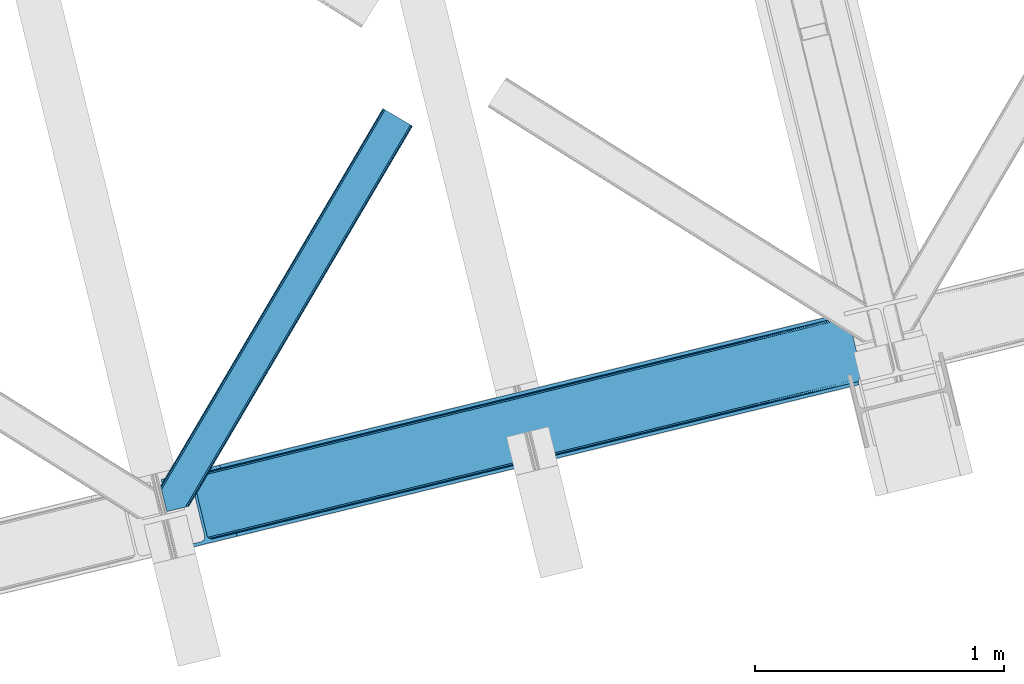
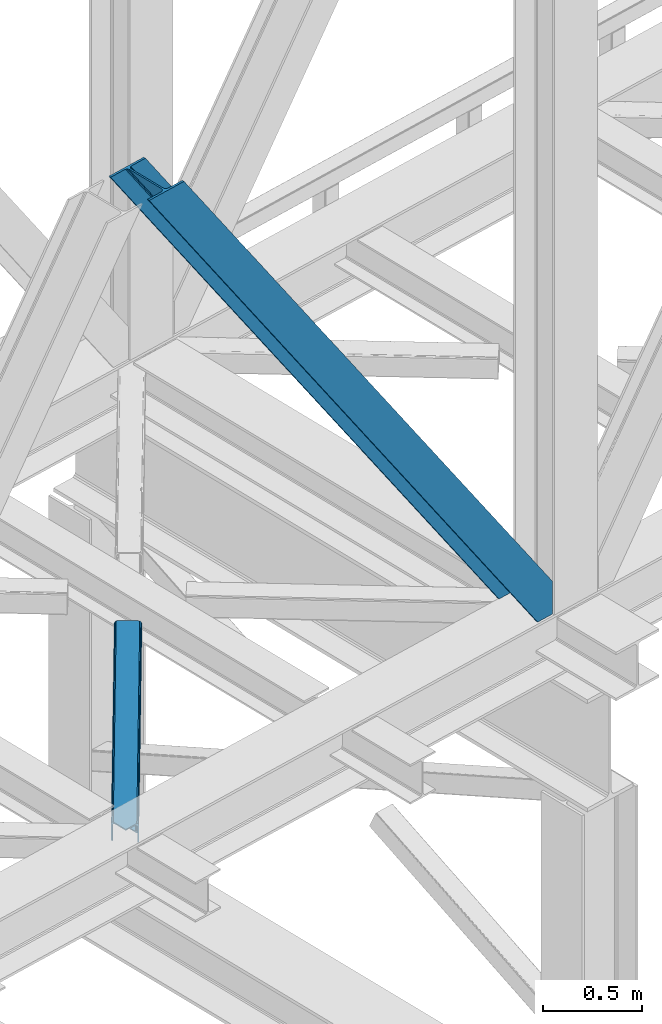
# One storey, part 27 of 93: 2 members.
"""IFC4 building model written with IfcOpenShell, lengths in millimetres."""

from ifc_helpers import new_model, entity, si_unit, converted_unit, derived_unit, direction, frame, origin, place, context, subcontext, project, spatial, triangles, type_object, element, save


model = new_model("IFC4")

# Units and contexts
model_context = context("Model", 3, precision=0.01, world=origin(), true_north=direction((6.12303176911189e-17, 1.0)))
plan_context = context("Plan", 3, precision=0.01, world=origin(), true_north=direction((6.12303176911189e-17, 1.0)))
body_context = subcontext(model_context, "Body", "Model", "MODEL_VIEW")
ifc_project = project(units=[si_unit("LENGTHUNIT", "METRE", prefix="MILLI"), si_unit("AREAUNIT", "SQUARE_METRE"), si_unit("VOLUMEUNIT", "CUBIC_METRE"), converted_unit("PLANEANGLEUNIT", "DEGREE", entity("IfcRatioMeasure", 0.0174532925199433), si_unit("PLANEANGLEUNIT", "RADIAN"), dimensions=[0, 0, 0, 0, 0, 0, 0]), si_unit("MASSUNIT", "GRAM", prefix="KILO"), derived_unit("MASSDENSITYUNIT", [(si_unit("MASSUNIT", "GRAM", prefix="KILO"), 1), (si_unit("LENGTHUNIT", "METRE"), -3)]), derived_unit("MOMENTOFINERTIAUNIT", [(si_unit("LENGTHUNIT", "METRE"), 4)]), si_unit("TIMEUNIT", "SECOND"), si_unit("FREQUENCYUNIT", "HERTZ"), si_unit("THERMODYNAMICTEMPERATUREUNIT", "DEGREE_CELSIUS"), derived_unit("THERMALTRANSMITTANCEUNIT", [(si_unit("MASSUNIT", "GRAM", prefix="KILO"), 1), (si_unit("THERMODYNAMICTEMPERATUREUNIT", "KELVIN"), -1), (si_unit("TIMEUNIT", "SECOND"), -3)]), derived_unit("VOLUMETRICFLOWRATEUNIT", [(si_unit("LENGTHUNIT", "METRE"), 3), (si_unit("TIMEUNIT", "SECOND"), -1)]), derived_unit("MASSFLOWRATEUNIT", [(si_unit("MASSUNIT", "GRAM", prefix="KILO"), 1), (si_unit("TIMEUNIT", "SECOND"), -1)]), derived_unit("ROTATIONALFREQUENCYUNIT", [(si_unit("TIMEUNIT", "SECOND"), -1)]), si_unit("ELECTRICCURRENTUNIT", "AMPERE"), si_unit("ELECTRICVOLTAGEUNIT", "VOLT"), si_unit("POWERUNIT", "WATT"), si_unit("FORCEUNIT", "NEWTON", prefix="KILO"), si_unit("ILLUMINANCEUNIT", "LUX"), si_unit("LUMINOUSFLUXUNIT", "LUMEN"), si_unit("LUMINOUSINTENSITYUNIT", "CANDELA"), derived_unit("USERDEFINED", [(si_unit("MASSUNIT", "GRAM", prefix="KILO"), -1), (si_unit("LENGTHUNIT", "METRE"), -2), (si_unit("TIMEUNIT", "SECOND"), 3), (si_unit("LUMINOUSFLUXUNIT", "LUMEN"), 1)]), derived_unit("LINEARVELOCITYUNIT", [(si_unit("LENGTHUNIT", "METRE"), 1), (si_unit("TIMEUNIT", "SECOND"), -1)]), si_unit("PRESSUREUNIT", "PASCAL"), derived_unit("USERDEFINED", [(si_unit("LENGTHUNIT", "METRE"), -2), (si_unit("MASSUNIT", "GRAM", prefix="KILO"), 1), (si_unit("TIMEUNIT", "SECOND"), -2)]), derived_unit("LINEARFORCEUNIT", [(si_unit("MASSUNIT", "GRAM", prefix="KILO"), 1), (si_unit("LENGTHUNIT", "METRE"), 1), (si_unit("TIMEUNIT", "SECOND"), -2), (si_unit("LENGTHUNIT", "METRE"), -1)]), derived_unit("PLANARFORCEUNIT", [(si_unit("MASSUNIT", "GRAM", prefix="KILO"), 1), (si_unit("LENGTHUNIT", "METRE"), 1), (si_unit("TIMEUNIT", "SECOND"), -2), (si_unit("LENGTHUNIT", "METRE"), -2)])], contexts=[model_context, plan_context])

# Site, building, storey
site_placement = place(None, origin())
site = spatial("IfcSite", under=ifc_project, at=site_placement, CompositionType="ELEMENT")
building_placement = place(site_placement, origin())
building = spatial("IfcBuilding", under=site, at=building_placement, CompositionType="ELEMENT")
storey_placement = place(building_placement, frame((0.0, 0.0, 15900.0)))
storey = spatial("IfcBuildingStorey", under=building, at=storey_placement, CompositionType="ELEMENT", Elevation=15900.0)

# Members
member_type_1 = type_object("IfcMemberType", PredefinedType="BRACE")
member_1_placement = place(storey_placement, frame((-57373.986328125, 3481.27180938721, 3694.99929199219)))
element("IfcMember", 1, at=member_1_placement, inside=storey, type_object=member_type_1, ObjectType="Steel Vertical Brace", PredefinedType="BRACE", context=body_context, shape_type="Tessellation", body=[
    triangles([(2824.17180175781, 696.209248352051, 0.781347656247817), (2824.8368774414, 695.2276222229, 1.0697021484375), (2823.33929443359, 694.862528228759, 0.0), (2821.44638671875, 702.635018920899, 0.0), (2812.37717285156, 692.190598297119, 19.5569458007813), (2812.37717285156, 692.190598297119, 0.0), (2386.756640625, 583.574263000488, 658.75048828125), (2392.34234619141, 580.919773864746, 662.07819213867), (2803.98698730468, 681.26248626709, 51.2480346679658), (2804.11256103515, 683.186496734619, 44.4996093749978), (2382.25924072265, 588.488497924805, 656.525042724606), (2808.48903808594, 690.37995300293, 26.4030395507798), (2805.01948242187, 685.664543151855, 38.2720825195283), (2805.58688964844, 687.218227386475, 34.3676696777329), (630.519653320313, 150.046073913574, 3288.98063964843), (624.69210205078, 150.036772155762, 3285.05529785156), (211.331286621091, 47.8653923034667, 3911.00081176758), (202.862036132814, 47.2113624572753, 3911.00081176758), (619.106396484371, 152.691261291504, 3281.72759399414), (195.034606933594, 49.3190826416017, 3911.00081176758), (614.608996582028, 157.60549621582, 3279.50447387695), (189.039624023433, 53.8679328918456, 3911.00081176758), (611.88358154297, 164.031266784668, 3278.7231262207), (185.788659667967, 60.1655136108398, 3911.00081176758), (2804.10325927734, 679.880593872071, 63.6403015136711), (2398.16524658203, 580.929075622559, 666.003533935545), (1956.25268554688, 473.208325195313, 1321.74955444336), (1950.42978515625, 473.1990234375, 1317.82188720703), (1508.51722412109, 365.478273010254, 1973.56790771484), (1514.34012451172, 365.487574768066, 1977.49324951172), (1066.60466308593, 257.757522583008, 2629.3116027832), (1072.42756347656, 257.76682434082, 2633.23694458008), (1944.84407958984, 475.853512573242, 1314.49418334961), (1502.93151855469, 368.132762145996, 1970.23787841797), (1061.01895751953, 260.41201171875, 2625.98389892578), (1940.3466796875, 480.767747497559, 1312.27106323242), (1498.43411865235, 373.046997070313, 1968.01475830078), (1056.52155761718, 265.326246643067, 2623.75845336914), (2379.53382568359, 594.913977813721, 655.74602050781), (1937.62126464843, 487.193518066406, 1311.48971557617), (1495.70870361328, 379.47276763916, 1967.23341064453), (1053.79614257813, 271.752017211914, 2622.97710571289), (2766.2637084961, 929.006666564941, 0.0), (2324.35114746093, 821.285625457764, 655.74602050781), (1882.43858642578, 713.565165710449, 1311.48971557617), (1440.53067626953, 605.844415283203, 1967.23341064453), (998.618115234371, 498.123664855957, 2622.97710571289), (556.705554199216, 390.402914428711, 3278.7231262207), (130.605981445311, 286.537161254883, 3911.00081176758), (303.265209960933, 70.2747802734375, 3911.00081176758), (2804.10325927734, 679.880593872071, 200.055230712889), (2807.14028320312, 667.239795684814, 200.120343017577), (2804.2985961914, 678.898386383056, 200.120343017577), (306.344091796876, 57.6444465637205, 3911.00081176758), (2807.14028320312, 667.239795684814, 0.0), (2804.2985961914, 678.898386383056, 0.0), (2804.0009399414, 682.092958831787, 0.0), (2804.11256103515, 683.186496734619, 2.42078247070094), (2804.71717529296, 685.456997680664, 5.12991943359157), (2805.58688964844, 687.218227386475, 5.67639770507594), (2807.01470947266, 689.087299346924, 4.89505004882813), (2808.48903808594, 690.37995300293, 3.35328369140552), (2811.03771972656, 691.772309875489, 0.0), (2705.52322998047, 642.46979598999, 0.0), (69.865502929686, 0.0, 3911.00081176758), (2794.37362060547, 677.509226989746, 0.0), (2802.00106201172, 681.140400695801, 0.0), (2702.44434814453, 655.099839019776, 0.0), (66.78662109375, 12.6303337097165, 3911.00081176758), (1480.00268554688, 357.116864776611, 1950.37164916992), (1034.29035644531, 248.469426727295, 2611.75686035156), (588.573376464839, 139.821988677978, 3273.1420715332), (158.715893554683, 35.039430999756, 3911.00081176758), (1925.71501464843, 465.764302825928, 1288.98643798828), (2371.42734375, 574.411740875244, 627.598901367186), (2376.60377197265, 577.083380126953, 631.526568603513), (2380.34307861328, 582.010695648193, 634.854272460936), (2381.53835449219, 595.402610778809, 637.858740234373), (2811.39583740234, 700.184877777099, 0.0), (2811.09353027344, 693.083567047119, 0.0), (2382.0732055664, 588.443733215332, 637.077392578125), (598.679736328122, 160.812567901611, 3283.40191040039), (599.21923828125, 153.853690338135, 3282.62056274414), (175.738110351558, 57.7156631469725, 3911.00081176758), (175.747412109376, 50.6283050537108, 3911.00081176758), (597.489111328126, 147.420943450928, 3280.39744262695), (172.519702148435, 43.8301734924316, 3911.00081176758), (593.749804687497, 142.493627929688, 3277.06973876953), (166.538671875001, 38.3560890197755, 3911.00081176758), (1936.36087646485, 479.796004486084, 1298.46260375976), (1935.82137451172, 486.755172729492, 1299.24395141601), (1490.10904541016, 378.107734680176, 1960.63148803711), (1490.64854736328, 371.148566436767, 1959.85014038086), (1044.93156738281, 262.501128387451, 2621.2353515625), (1044.39671630859, 269.460296630859, 2622.01669921875), (1934.62609863281, 473.363257598877, 1296.23948364258), (1488.91376953125, 364.71581954956, 1957.62469482422), (1043.20144042969, 256.068381500244, 2619.01223144531), (1930.89144287109, 468.435942077637, 1292.91177978515), (1485.17911376953, 359.78850402832, 1954.2969909668), (1039.46213378906, 251.141065979004, 2615.68220214844), (2756.21315917969, 926.556525421142, 0.0), (2326.35567626953, 821.774258422852, 637.858740234373), (1434.9263671875, 604.479382324219, 1960.63148803711), (1880.64334716797, 713.126820373535, 1299.24395141601), (989.214038085935, 495.831944274903, 2622.01669921875), (543.501708984375, 387.184215545654, 3283.40191040039), (120.555432128902, 284.087310791016, 3911.00081176758), (2752.67849121094, 932.72359085083, 0.0), (2753.40867919922, 934.106936645508, 0.0), (2752.02736816406, 933.862474822998, 0.0), (2764.37080078125, 936.778866577149, 0.0), (2753.40867919922, 934.106936645508, 19.5569458007813), (2765.86838378906, 937.143960571289, 1.0697021484375), (2765.72885742188, 935.965544128418, 0.781347656247817), (2325.54642333985, 834.677540588379, 658.75048828125), (2749.12056884765, 933.923517608642, 26.4030395507798), (2745.08825683594, 935.395230102539, 34.3676696777329), (2323.81629638671, 828.244793701172, 656.525042724606), (2743.51160888671, 936.560275268555, 38.5441589355469), (556.166052246095, 397.361791992188, 3279.50447387695), (130.5966796875, 293.624228668213, 3911.00081176758), (557.900830078121, 403.794829559326, 3281.72759399414), (133.824389648435, 300.422360229492, 3911.00081176758), (561.635485839841, 408.721854400635, 3285.05529785156), (139.805419921875, 305.896444702149, 3911.00081176758), (566.811914062499, 411.393493652344, 3288.98063964843), (147.628198242186, 309.213102722168, 3911.00081176758), (2740.93037109375, 939.947568511963, 51.2480346679658), (2740.39552001953, 941.228304290771, 63.6403015136711), (2329.28572998047, 839.60485610962, 662.07819213867), (2334.45750732422, 842.276495361328, 666.003533935545), (2742.09309082031, 938.42149887085, 45.5251281738274), (1881.90373535156, 720.524043273926, 1312.27106323242), (1439.9911743164, 612.80329284668, 1968.01475830078), (998.07861328125, 505.082542419434, 2623.75845336914), (1883.63386230468, 726.956790161133, 1314.49418334961), (1441.72130126953, 619.236039733887, 1970.23787841797), (999.813391113283, 511.515289306641, 2625.98389892578), (1887.37316894531, 731.884105682373, 1317.82188720703), (1445.46060791016, 624.163355255127, 1973.56790771484), (1003.548046875, 516.442604827881, 2629.3116027832), (1892.54959716797, 734.555744934082, 1321.74955444336), (1450.63703613281, 626.834994506836, 1977.49324951172), (1008.72447509765, 519.11424407959, 2633.23694458008), (2740.39552001953, 941.228304290771, 200.055230712889), (239.557470703126, 331.622200012207, 3911.00081176758), (2749.12056884765, 933.923517608642, 3.35328369140552), (2745.08825683594, 935.395230102539, 5.67639770507594), (2747.2230102539, 934.392675018311, 4.89272460937354), (2743.51160888671, 936.560275268555, 5.12991943359157), (2740.11646728515, 942.189001464843, 0.0), (2741.92565917969, 938.297378540039, 2.42078247070094), (2740.11646728515, 942.189001464843, 200.120343017577), (2741.32104492188, 939.215927124023, 0.0), (2323.63026123046, 828.2000289917, 637.077392578125), (2319.13286132812, 833.113973236084, 634.854272460936), (2313.54715576172, 835.768462371826, 631.526568603513), (2307.72425537109, 835.759160614014, 627.598901367186), (2730.67053222656, 938.856646728515, 0.0), (2739.1072265625, 939.141222381591, 0.0), (524.870288085935, 401.16969909668, 3273.1420715332), (530.693188476558, 401.17871017456, 3277.06973876953), (103.477404785153, 297.041171264648, 3911.00081176758), (95.0081542968765, 296.387141418457, 3911.00081176758), (536.278894042967, 398.524221038818, 3280.39744262695), (111.309484863283, 294.933451080322, 3911.00081176758), (540.77629394531, 393.609986114502, 3282.62056274414), (117.304467773436, 290.384600830078, 3911.00081176758), (1867.83482666015, 727.12102432251, 1292.91177978515), (1862.01192626953, 727.112013244629, 1288.98643798828), (1416.29494628906, 618.464575195312, 1950.37164916992), (1422.11784667968, 618.473586273193, 1954.2969909668), (970.582617187501, 509.817137145996, 2611.75686035156), (976.405517578125, 509.826148223877, 2615.68220214844), (1873.42053222656, 724.466535186768, 1296.23948364258), (1427.70355224609, 615.819097137452, 1957.62469482422), (981.991223144527, 507.171659088135, 2619.01223144531), (1877.9179321289, 719.552300262451, 1298.46260375976), (1432.20560302735, 610.905152893066, 1959.85014038086), (986.488623046876, 502.257424163819, 2621.2353515625), (2737.27478027344, 953.847592163086, 200.120343017577), (236.478588867183, 344.252533721924, 3911.00081176758), (2737.27478027344, 953.847592163086, 0.0), (0.0, 286.608087158203, 3911.00081176758), (3.07888183593604, 273.977753448487, 3911.00081176758), (2635.65772705078, 929.077592468262, 0.0), (2638.73660888672, 916.447258758545, 0.0)], [[1, 2, 3], [3, 4, 1], [2, 5, 6], [6, 3, 2], [7, 8, 9], [9, 10, 7], [11, 12, 5], [5, 1, 11], [5, 2, 1], [11, 7, 13], [13, 14, 11], [14, 12, 11], [15, 16, 17], [18, 17, 16], [16, 19, 18], [20, 18, 19], [19, 21, 20], [22, 20, 21], [21, 23, 22], [24, 22, 23], [10, 13, 7], [25, 9, 8], [8, 26, 25], [26, 8, 27], [28, 27, 8], [27, 28, 29], [29, 30, 27], [30, 29, 31], [31, 32, 30], [32, 31, 16], [16, 15, 32], [8, 7, 28], [33, 28, 7], [28, 33, 29], [34, 29, 33], [29, 34, 31], [35, 31, 34], [31, 35, 19], [19, 16, 31], [7, 11, 36], [36, 33, 7], [33, 36, 37], [37, 34, 33], [34, 37, 35], [38, 35, 37], [35, 38, 19], [21, 19, 38], [1, 4, 39], [39, 11, 1], [11, 39, 40], [40, 36, 11], [36, 40, 41], [41, 37, 36], [37, 41, 42], [42, 38, 37], [38, 42, 21], [23, 21, 42], [4, 43, 44], [45, 39, 44], [41, 40, 45], [41, 45, 46], [44, 39, 4], [45, 40, 39], [42, 41, 46], [46, 47, 42], [47, 48, 23], [49, 24, 48], [47, 23, 42], [48, 24, 23], [50, 51, 30], [30, 32, 50], [32, 15, 50], [17, 50, 15], [27, 30, 51], [51, 25, 26], [26, 27, 51], [52, 53, 54], [53, 51, 50], [50, 54, 53], [52, 55, 53], [56, 53, 55], [56, 9, 25], [56, 57, 58], [58, 10, 56], [10, 9, 56], [59, 60, 14], [14, 13, 59], [10, 58, 59], [60, 61, 12], [12, 14, 60], [5, 62, 63], [63, 6, 5], [5, 12, 62], [61, 62, 12], [13, 10, 59], [25, 51, 53], [53, 56, 25], [54, 64, 52], [54, 65, 64], [64, 55, 52], [56, 66, 67], [55, 66, 56], [67, 57, 56], [64, 66, 55], [64, 68, 66], [68, 64, 65], [65, 69, 68], [69, 70, 68], [71, 69, 72], [69, 71, 70], [69, 73, 72], [74, 68, 70], [66, 68, 75], [74, 75, 68], [67, 76, 58], [76, 77, 59], [59, 58, 76], [76, 67, 66], [78, 79, 80], [81, 60, 59], [81, 80, 62], [62, 61, 81], [61, 60, 81], [80, 63, 62], [59, 77, 81], [80, 81, 78], [82, 83, 84], [85, 84, 83], [83, 86, 85], [87, 85, 86], [86, 88, 87], [89, 87, 88], [88, 72, 89], [73, 89, 72], [66, 75, 76], [58, 57, 67], [78, 81, 90], [90, 91, 78], [91, 90, 92], [93, 92, 90], [92, 93, 94], [94, 95, 92], [95, 94, 83], [83, 82, 95], [81, 77, 90], [96, 90, 77], [90, 96, 93], [97, 93, 96], [93, 97, 94], [98, 94, 97], [94, 98, 83], [86, 83, 98], [77, 76, 99], [99, 96, 77], [96, 99, 100], [100, 97, 96], [97, 100, 101], [101, 98, 97], [98, 101, 86], [88, 86, 101], [76, 75, 99], [74, 99, 75], [99, 74, 70], [70, 100, 99], [100, 70, 71], [71, 101, 100], [101, 71, 88], [72, 88, 71], [102, 79, 78], [91, 103, 78], [104, 105, 91], [104, 91, 92], [78, 103, 102], [91, 105, 103], [106, 104, 92], [92, 95, 106], [95, 82, 107], [84, 108, 82], [95, 107, 106], [82, 108, 107], [109, 102, 110], [6, 79, 80], [6, 80, 63], [110, 111, 109], [3, 79, 6], [79, 4, 102], [3, 4, 79], [43, 102, 4], [102, 112, 110], [112, 102, 43], [113, 114, 110], [112, 110, 114], [114, 115, 112], [43, 112, 115], [116, 117, 118], [119, 115, 113], [113, 116, 119], [113, 117, 116], [115, 114, 113], [118, 120, 116], [48, 121, 122], [122, 49, 48], [121, 123, 124], [124, 122, 121], [123, 125, 126], [126, 124, 123], [125, 127, 128], [128, 126, 125], [129, 130, 131], [132, 131, 130], [133, 116, 120], [116, 133, 129], [131, 116, 129], [43, 115, 119], [119, 44, 43], [44, 119, 45], [134, 45, 119], [45, 134, 46], [135, 46, 134], [46, 135, 47], [136, 47, 135], [47, 136, 121], [121, 48, 47], [119, 116, 134], [137, 134, 116], [134, 137, 135], [138, 135, 137], [135, 138, 139], [139, 136, 135], [136, 139, 121], [123, 121, 139], [116, 131, 140], [140, 137, 116], [137, 140, 141], [141, 138, 137], [138, 141, 142], [142, 139, 138], [139, 142, 123], [125, 123, 142], [131, 132, 140], [143, 140, 132], [140, 143, 141], [144, 141, 143], [141, 144, 142], [145, 142, 144], [142, 145, 125], [127, 125, 145], [144, 146, 147], [147, 127, 145], [127, 147, 128], [145, 144, 147], [146, 144, 143], [143, 132, 146], [130, 146, 132], [113, 110, 111], [148, 117, 113], [149, 118, 117], [117, 148, 150], [151, 133, 120], [118, 149, 151], [151, 120, 118], [152, 133, 153], [152, 129, 133], [146, 130, 154], [152, 154, 130], [130, 129, 152], [153, 155, 152], [151, 153, 133], [117, 150, 149], [111, 148, 113], [156, 150, 148], [156, 149, 150], [148, 109, 156], [148, 111, 109], [156, 157, 151], [151, 149, 156], [103, 156, 109], [158, 159, 160], [158, 153, 151], [158, 161, 153], [161, 155, 153], [151, 157, 158], [160, 161, 158], [162, 163, 164], [164, 165, 162], [163, 166, 167], [167, 164, 163], [166, 168, 169], [169, 167, 166], [168, 107, 108], [108, 169, 168], [109, 102, 103], [159, 158, 170], [170, 171, 159], [171, 170, 172], [173, 172, 170], [172, 173, 174], [175, 174, 173], [174, 175, 162], [163, 162, 175], [158, 157, 170], [176, 170, 157], [170, 176, 173], [177, 173, 176], [173, 177, 175], [178, 175, 177], [175, 178, 166], [166, 163, 175], [157, 156, 179], [179, 176, 157], [176, 179, 180], [180, 177, 176], [177, 180, 181], [181, 178, 177], [178, 181, 166], [168, 166, 181], [156, 103, 179], [105, 179, 103], [179, 105, 104], [104, 180, 179], [180, 104, 181], [106, 181, 104], [181, 106, 168], [107, 168, 106], [146, 154, 147], [154, 182, 183], [183, 147, 154], [154, 152, 184], [184, 182, 154], [108, 84, 49], [87, 89, 18], [73, 65, 54], [69, 65, 73], [89, 73, 17], [84, 85, 22], [85, 87, 20], [167, 126, 164], [185, 165, 183], [165, 164, 128], [185, 186, 165], [167, 169, 124], [169, 108, 122], [49, 84, 24], [17, 18, 89], [22, 85, 20], [18, 20, 87], [22, 24, 84], [54, 17, 73], [54, 50, 17], [128, 164, 126], [124, 169, 122], [49, 122, 108], [124, 126, 167], [128, 183, 165], [183, 128, 147], [152, 160, 184], [155, 161, 152], [152, 161, 160], [160, 187, 184], [187, 160, 188], [183, 187, 185], [187, 183, 182], [184, 187, 182], [172, 186, 188], [162, 186, 174], [162, 165, 186], [172, 174, 186], [188, 171, 172], [159, 171, 188], [188, 160, 159], [187, 188, 185], [186, 185, 188]]),
])
member_type_2 = type_object("IfcMemberType", PredefinedType="BRACE")
member_2_placement = place(storey_placement, frame((-57375.3955444336, 3638.09770202637, 3511.0000579834)))
element("IfcMember", 2, at=member_2_placement, inside=storey, type_object=member_type_2, ObjectType="Steel Horizontal Brace", PredefinedType="BRACE", context=body_context, shape_type="Tessellation", body=[
    triangles([(154.446386718751, 124.708666992188, 0.0), (118.769494628905, 271.071535491943, 0.0), (998.971582031249, 1559.19843292236, 0.0), (908.488732910155, 1612.46901855469, 0.0), (1004.74332275391, 1555.80096588135, 1.33247680664135), (156.725317382814, 115.37377166748, 1.33247680664135), (1009.63604736328, 1552.92090911865, 5.12526855468968), (158.650781249999, 107.459719848633, 5.12526855468968), (1012.90561523438, 1550.99602661133, 10.8028289794929), (159.943725585938, 102.171670532227, 10.8028289794929), (1014.05438232422, 1550.3204864502, 17.5000946044929), (160.394860839842, 100.314807128907, 17.5000946044929), (902.716992187503, 1615.8664855957, 1.33247680664135), (116.495214843751, 280.406721496582, 1.33247680664135), (114.574401855469, 288.275717926026, 5.17061462402489), (897.824267578122, 1618.74712371826, 5.12526855468968), (114.499987792966, 288.596628570557, 5.32641906738354), (894.554699707034, 1620.67142486572, 10.8028289794929), (109.625866699222, 287.409201049805, 10.8028289794929), (893.405932617185, 1621.34696502686, 17.5000946044929), (107.821325683595, 286.969111633301, 17.5000946044929), (113.527954101563, 288.35972442627, 18.5197998046897), (114.499987792966, 288.596628570557, 17.5198608398459), (114.42557373047, 288.578606414795, 17.9023956298843), (114.216284179689, 288.527156066895, 18.2279571533218), (113.900024414063, 288.450416564941, 18.4442230224631), (107.821325683595, 286.969111633301, 18.5197998046897), (115.695263671878, 283.683556365967, 17.5198608398459), (115.625500488284, 283.800409698486, 17.8035644531265), (115.565039062501, 283.740529632569, 17.8570495605491), (115.323193359378, 283.495777130127, 18.0768035888686), (115.067395019534, 283.23939743042, 18.3081848144539), (114.834851074222, 283.003074645996, 18.5197998046897), (0.0, 103.824767303467, 18.5197998046897), (2.73471679687646, 92.5989990234375, 18.5197998046897), (893.405932617185, 1621.34696502686, 122.500662231447), (0.0, 103.824767303467, 122.500662231447), (908.488732910155, 1612.46901855469, 139.999594116212), (902.716992187503, 1615.8664855957, 138.667117309571), (3.66954345702834, 88.7660934448245, 138.667117309571), (5.94847412109084, 79.4309074401858, 139.999594116212), (897.824267578122, 1618.74712371826, 134.874325561526), (1.73942871093459, 96.6798545837405, 134.874325561526), (894.554699707034, 1620.67142486572, 129.197927856447), (0.451135253904795, 101.967903900147, 129.197927856447), (899.438122558597, 1617.79601898193, 24.4996673583992), (2.37659912109666, 94.0672233581545, 24.4996673583992), (900.586889648439, 1617.11989746094, 17.8035644531265), (903.856457519534, 1615.19559631348, 12.1260040283232), (914.52092285156, 1608.9174911499, 6.99957275390625), (908.749182128908, 1612.31495819092, 8.3320495605476), (118.871813964841, 270.64917755127, 8.3320495605476), (121.150744628903, 261.313991546631, 6.99957275390625), (116.946350097656, 278.562938690186, 12.1260040283232), (152.069787597655, 134.4662109375, 6.99957275390625), (992.939392089844, 1562.74996032715, 6.99957275390625), (156.274182128909, 117.217263793946, 12.1260040283232), (154.344067382815, 125.131024932862, 8.3320495605476), (157.520617675778, 112.096646118164, 17.5198608398459), (160.394860839842, 100.314807128907, 17.5198608398459), (899.438122558597, 1617.79601898193, 115.501089477541), (2.37659912109666, 94.0672233581545, 115.501089477541), (900.586889648439, 1617.11989746094, 122.196029663086), (2.83238525390334, 92.2103599548341, 122.196029663086), (903.856457519534, 1615.19559631348, 127.87475280762), (4.12067871094041, 86.9223106384279, 127.87475280762), (908.749182128908, 1612.31495819092, 131.667544555665), (6.05079345703416, 79.0085494995119, 131.667544555665), (914.52092285156, 1608.9174911499, 133.000021362306), (8.3250732421875, 69.6733634948732, 133.000021362306), (25.310083007811, 0.0, 133.000021362306), (25.310083007811, 0.0, 139.999594116212), (90.3665771484375, 15.8580436706543, 139.999594116212), (998.971582031249, 1559.19843292236, 139.999594116212), (1014.05438232422, 1550.3204864502, 122.500662231447), (1012.90561523438, 1550.99602661133, 129.197927856447), (114.076757812501, 21.6376327514649, 122.500662231447), (112.267565917966, 21.1978340148926, 129.197927856447), (1009.63604736328, 1552.92090911865, 134.874325561526), (107.12834472656, 19.9450035095215, 134.874325561526), (1004.74332275391, 1555.80096588135, 138.667117309571), (99.435791015625, 18.0698272705081, 138.667117309571), (159.664672851563, 99.0785453796389, 18.5197998046897), (114.076757812501, 21.6376327514649, 18.5197998046897), (103.161145019534, 18.9779113769532, 18.5197998046897), (156.929956054686, 110.304313659668, 18.5197998046897), (1008.02219238281, 1553.87143249512, 24.4996673583992), (1006.87342529297, 1554.54755401611, 17.8035644531265), (1003.60385742188, 1556.47185516357, 12.1260040283232), (998.711132812503, 1559.35249328613, 8.3320495605476), (104.588964843751, 19.325855255127, 24.4996673583992), (1003.60385742188, 1556.47185516357, 127.87475280762), (1008.02219238281, 1553.87143249512, 115.501089477541), (1006.87342529297, 1554.54755401611, 122.196029663086), (992.939392089844, 1562.74996032715, 133.000021362306), (998.711132812503, 1559.35249328613, 131.667544555665), (102.784423828125, 18.8860565185546, 122.196029663086), (80.8787841796875, 13.5462661743163, 133.000021362306), (89.9526489257842, 15.7580497741701, 131.667544555665), (97.6452026367188, 17.6329353332521, 127.87475280762), (104.588964843751, 19.325855255127, 115.501089477541)], [[1, 2, 3], [4, 3, 2], [3, 5, 1], [6, 1, 5], [5, 7, 6], [8, 6, 7], [7, 9, 8], [10, 8, 9], [9, 11, 10], [12, 10, 11], [13, 14, 15], [16, 15, 17], [17, 18, 16], [17, 19, 18], [20, 18, 19], [19, 21, 20], [15, 16, 13], [13, 4, 14], [2, 14, 4], [22, 23, 24], [22, 25, 26], [27, 21, 22], [24, 25, 22], [23, 22, 21], [21, 19, 23], [17, 23, 19], [23, 28, 29], [29, 24, 23], [25, 24, 30], [26, 25, 31], [22, 26, 32], [32, 33, 22], [31, 32, 26], [30, 31, 25], [29, 30, 24], [34, 33, 35], [33, 34, 27], [22, 33, 27], [27, 20, 21], [36, 27, 37], [27, 36, 20], [27, 34, 37], [38, 39, 40], [40, 41, 38], [39, 42, 43], [43, 40, 39], [42, 44, 45], [45, 43, 42], [44, 36, 37], [37, 45, 44], [46, 47, 33], [33, 48, 46], [33, 31, 48], [47, 35, 33], [49, 48, 28], [50, 51, 52], [52, 53, 50], [51, 49, 54], [54, 52, 51], [28, 54, 49], [53, 55, 56], [56, 50, 53], [55, 2, 1], [54, 17, 14], [52, 14, 2], [52, 2, 53], [55, 53, 2], [17, 28, 23], [54, 28, 17], [52, 54, 14], [57, 58, 6], [58, 1, 6], [1, 58, 55], [8, 57, 6], [8, 59, 57], [10, 59, 8], [10, 60, 59], [46, 61, 47], [62, 47, 61], [61, 63, 62], [64, 62, 63], [63, 65, 64], [66, 64, 65], [65, 67, 66], [68, 66, 67], [67, 69, 68], [70, 68, 69], [66, 43, 64], [71, 72, 70], [72, 41, 70], [40, 68, 41], [66, 68, 40], [68, 70, 41], [66, 40, 43], [37, 34, 62], [45, 64, 43], [62, 64, 37], [64, 45, 37], [34, 47, 62], [34, 35, 47], [41, 73, 74], [73, 41, 72], [74, 38, 41], [75, 76, 77], [78, 77, 76], [76, 79, 78], [80, 78, 79], [79, 81, 80], [82, 80, 81], [81, 74, 82], [73, 82, 74], [60, 75, 77], [60, 11, 75], [77, 83, 60], [77, 84, 83], [84, 85, 83], [86, 83, 85], [87, 88, 59], [88, 89, 57], [57, 59, 88], [89, 90, 58], [58, 57, 89], [90, 56, 55], [55, 58, 90], [87, 86, 91], [85, 91, 86], [9, 89, 88], [87, 75, 11], [9, 88, 11], [9, 7, 89], [88, 87, 11], [89, 7, 5], [56, 3, 4], [3, 90, 5], [90, 3, 56], [90, 89, 5], [76, 92, 79], [93, 75, 87], [75, 94, 76], [94, 75, 93], [76, 94, 92], [74, 95, 38], [81, 79, 92], [92, 96, 81], [96, 95, 74], [74, 81, 96], [49, 13, 16], [4, 50, 56], [4, 51, 50], [51, 4, 13], [49, 51, 13], [46, 20, 36], [18, 48, 49], [16, 18, 49], [48, 18, 20], [46, 48, 20], [39, 65, 42], [38, 95, 69], [69, 67, 38], [67, 65, 39], [39, 38, 67], [44, 42, 65], [36, 61, 46], [63, 36, 44], [36, 63, 61], [63, 44, 65], [97, 78, 80], [98, 73, 72], [72, 71, 98], [98, 99, 73], [99, 82, 73], [100, 82, 99], [80, 82, 100], [97, 77, 78], [101, 77, 97], [80, 100, 97], [84, 91, 85], [101, 84, 77], [91, 84, 101], [98, 70, 95], [98, 71, 70], [69, 95, 70], [95, 96, 99], [99, 98, 95], [96, 92, 100], [100, 99, 96], [92, 94, 97], [97, 100, 92], [94, 93, 101], [101, 97, 94], [93, 87, 91], [91, 101, 93]]),
])

save(model, "model.ifc")
